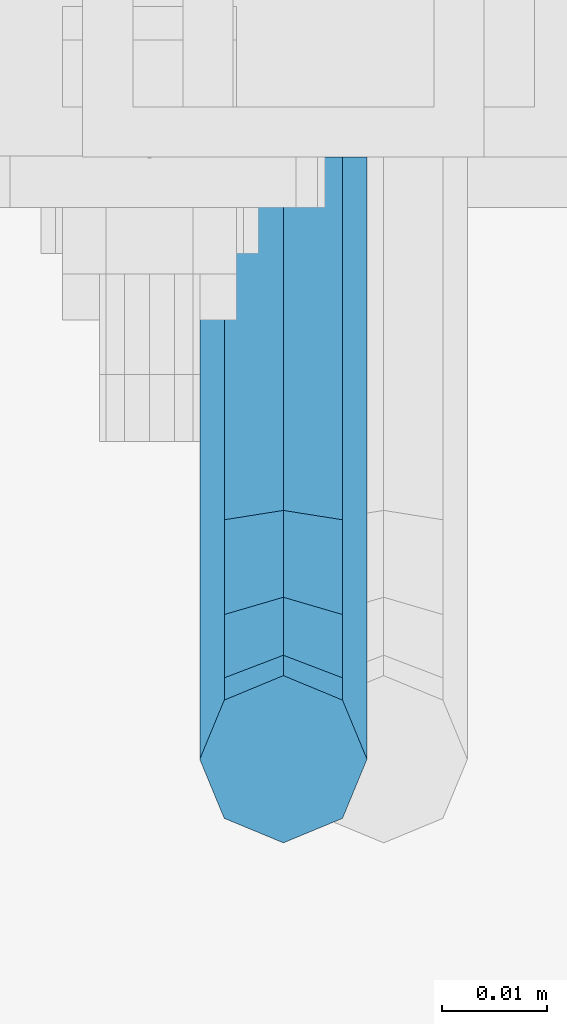
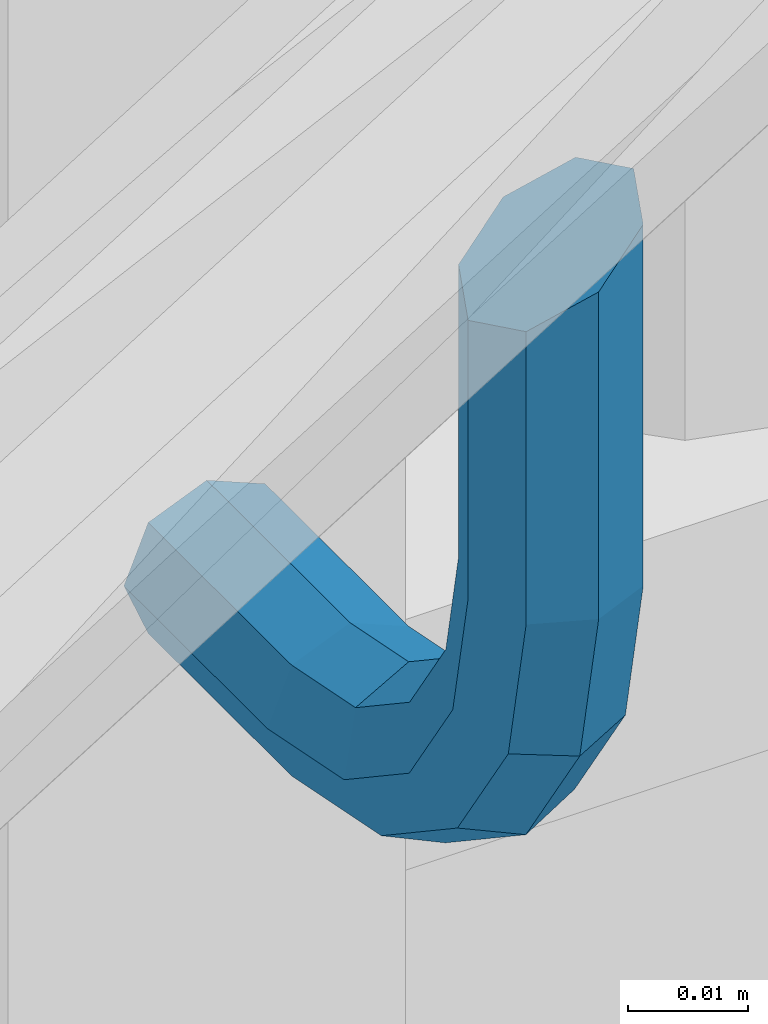
# One storey, part 1193 of 1876: 1 beam, 1 element without a shape of its own.
"""IFC2X3 building model written with IfcOpenShell, lengths in millimetres."""

from ifc_helpers import new_model, si_unit, frame, origin_with_axes, place, context, subcontext, project, spatial, faceted_brep, material, type_object, element, aggregate, save


model = new_model("IFC2X3")

# Units and contexts
model_context = context("Model", 3, precision=1e-05, world=origin_with_axes())
body_context = subcontext(model_context, "Body", "Model", "MODEL_VIEW")
ifc_project = project(units=[si_unit("LENGTHUNIT", "METRE", prefix="MILLI"), si_unit("AREAUNIT", "SQUARE_METRE"), si_unit("VOLUMEUNIT", "CUBIC_METRE"), si_unit("MASSUNIT", "GRAM", prefix="KILO"), si_unit("TIMEUNIT", "SECOND"), si_unit("PLANEANGLEUNIT", "RADIAN"), si_unit("SOLIDANGLEUNIT", "STERADIAN"), si_unit("THERMODYNAMICTEMPERATUREUNIT", "DEGREE_CELSIUS"), si_unit("LUMINOUSINTENSITYUNIT", "LUMEN")], contexts=[model_context])

# Site, building, storey
site_placement = place(None, origin_with_axes())
site = spatial("IfcSite", under=ifc_project, at=site_placement, CompositionType="ELEMENT")
building_placement = place(site_placement, origin_with_axes())
building = spatial("IfcBuilding", under=site, at=building_placement, Name="Undefined", CompositionType="ELEMENT")
storey_placement = place(building_placement, origin_with_axes())
storey = spatial("IfcBuildingStorey", under=building, at=storey_placement, Name="Undefined", CompositionType="ELEMENT", Elevation=0.0)

# Assembly, beam
assembly_placement = place(storey_placement, origin_with_axes())
assembly = element("IfcElementAssembly", 1, at=assembly_placement, inside=storey, Name="RAIL", AssemblyPlace="NOTDEFINED", PredefinedType="RIGID_FRAME")
ifc_material = material(Name="STEEL/A36")
beam_type = type_object("IfcBeamType", PredefinedType="NOTDEFINED")
beam_placement = place(assembly_placement, frame((4918.0749972412, -4800.60000114554, 18088.4707730938), z_axis=(-1.0, 0.0, 0.0), x_axis=(0.0, -1.0, 0.0)))
beam = element("IfcBeam", 2, at=beam_placement, type_object=beam_type, material=ifc_material, Name="BRACKET", context=body_context, shape_type="Brep", body=[
    faceted_brep([(0.0, -5.61266007566822, 5.61266007566883), (0.0, 0.0, 7.9375), (0.0, 5.61266007566822, 5.61266007566883), (0.0, 7.9375, 0.0), (0.0, 5.61266007566822, -5.61266007566883), (0.0, 0.0, -7.9375), (0.0, -5.61266007566822, -5.61266007566883), (0.0, -7.9375, 0.0), (23.8125, -5.61266007566883, -5.61266007566792), (23.8125, -7.9375, 0.0), (23.8125, -5.61266007566883, 5.61266007566792), (23.8125, 0.0, 7.9375), (23.8125, 5.61266007566883, 5.61266007566792), (23.8125, 7.9375, 0.0), (23.8125, 5.61266007566883, -5.61266007566792), (23.8125, 0.0, -7.9375), (36.5702095103998, 2.53766620105671, -7.9375), (38.7180815328556, -2.64775556579843, -5.61266007566792), (39.6077592547981, -4.79562758825341, 0.0), (38.7180815328556, -2.64775556579843, 5.61266007566792), (36.5702095103998, 2.53766620105671, 7.9375), (34.4223374879448, 7.72308796790821, 5.61266007566792), (33.5326597660023, 9.87095999036319, 0.0), (34.4223374879448, 7.72308796790821, -5.61266007566792), (43.4169233967659, 13.733078129113, -5.61266007566792), (47.3856733967659, 9.76432812911298, -7.9375), (41.773013321098, 15.3769882047818, 0.0), (43.4169233967659, 13.733078129113, 5.61266007566792), (47.3856733967659, 9.76432812911298, 7.9375), (51.3544233967659, 5.79557812911298, 5.61266007566792), (52.9983334724348, 4.15166805344415, 0.0), (51.3544233967659, 5.79557812911298, -5.61266007566792), (54.6123353248231, 20.5797920154801, -7.9375), (59.7977570916764, 18.4319199930251, -5.61266007566792), (49.4269135579698, 22.727664037935, -5.61266007566792), (47.2790415355148, 23.6173417598766, 0.0), (49.4269135579698, 22.727664037935, 5.61266007566792), (54.6123353248231, 20.5797920154801, 7.9375), (59.7977570916764, 18.4319199930251, 5.61266007566792), (61.9456291141314, 17.5422422710835, 0.0), (62.7626616015468, 33.3375015258789, -5.61266007566792), (65.0875015258789, 33.3375015258789, 0.0), (57.1500015258789, 33.3375015258789, -7.9375), (51.5373414502101, 33.3375015258789, -5.61266007566792), (49.2125015258789, 33.3375015258789, 0.0), (51.5373414502101, 33.3375015258789, 5.61266007566792), (57.1500015258789, 33.3375015258789, 7.9375), (62.7626616015468, 33.3375015258789, 5.61266007566792), (65.0875015258789, 66.4903820289292, 0.0), (62.7626616015468, 63.0131702244908, 5.61266007566837), (57.1500015258789, 61.5728619358488, 7.9375), (51.537341450211, 63.0131702244908, 5.61266007566837), (49.2125015258789, 66.4903820289292, 0.0), (51.537341450211, 69.9675938333676, -5.61266007566837), (57.1500015258789, 71.4079021220132, -7.9375), (62.7626616015468, 69.9675938333676, -5.61266007566837)], [[[0, 1, 2, 3, 4, 5, 6, 7]], [[7, 6, 8, 9]], [[0, 7, 9, 10]], [[1, 0, 10, 11]], [[2, 1, 11, 12]], [[3, 2, 12, 13]], [[4, 3, 13, 14]], [[5, 4, 14, 15]], [[6, 5, 15, 8]], [[8, 15, 16, 17]], [[9, 8, 17, 18]], [[10, 9, 18, 19]], [[11, 10, 19, 20]], [[12, 11, 20, 21]], [[13, 12, 21, 22]], [[14, 13, 22, 23]], [[15, 14, 23, 16]], [[23, 24, 25, 16]], [[22, 26, 24, 23]], [[21, 27, 26, 22]], [[20, 28, 27, 21]], [[19, 29, 28, 20]], [[18, 30, 29, 19]], [[17, 31, 30, 18]], [[16, 25, 31, 17]], [[25, 32, 33, 31]], [[24, 34, 32, 25]], [[26, 35, 34, 24]], [[27, 36, 35, 26]], [[28, 37, 36, 27]], [[29, 38, 37, 28]], [[30, 39, 38, 29]], [[31, 33, 39, 30]], [[33, 40, 41, 39]], [[32, 42, 40, 33]], [[34, 43, 42, 32]], [[35, 44, 43, 34]], [[36, 45, 44, 35]], [[37, 46, 45, 36]], [[38, 47, 46, 37]], [[39, 41, 47, 38]], [[47, 41, 48, 49]], [[46, 47, 49, 50]], [[45, 46, 50, 51]], [[44, 45, 51, 52]], [[43, 44, 52, 53]], [[42, 43, 53, 54]], [[40, 42, 54, 55]], [[41, 40, 55, 48]], [[54, 53, 52, 51, 50, 49, 48, 55]]]),
])
aggregate(assembly, [beam])

save(model, "model.ifc")
